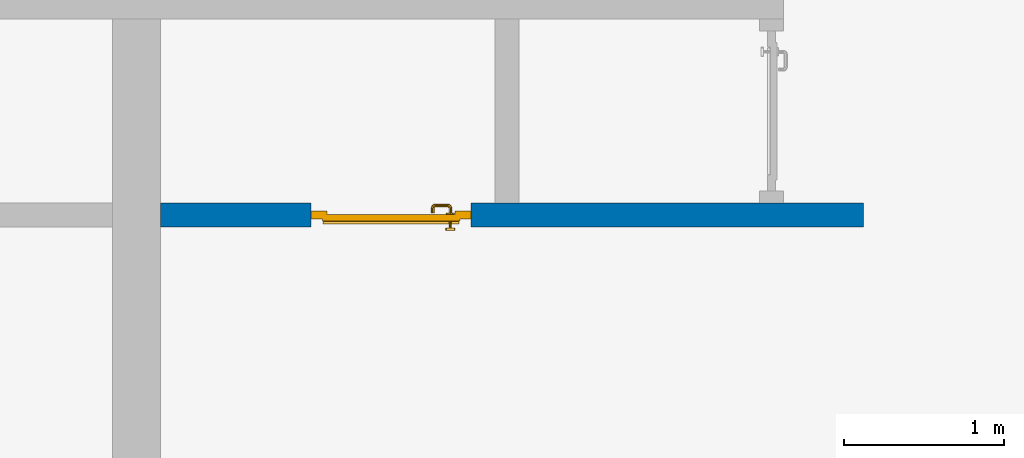
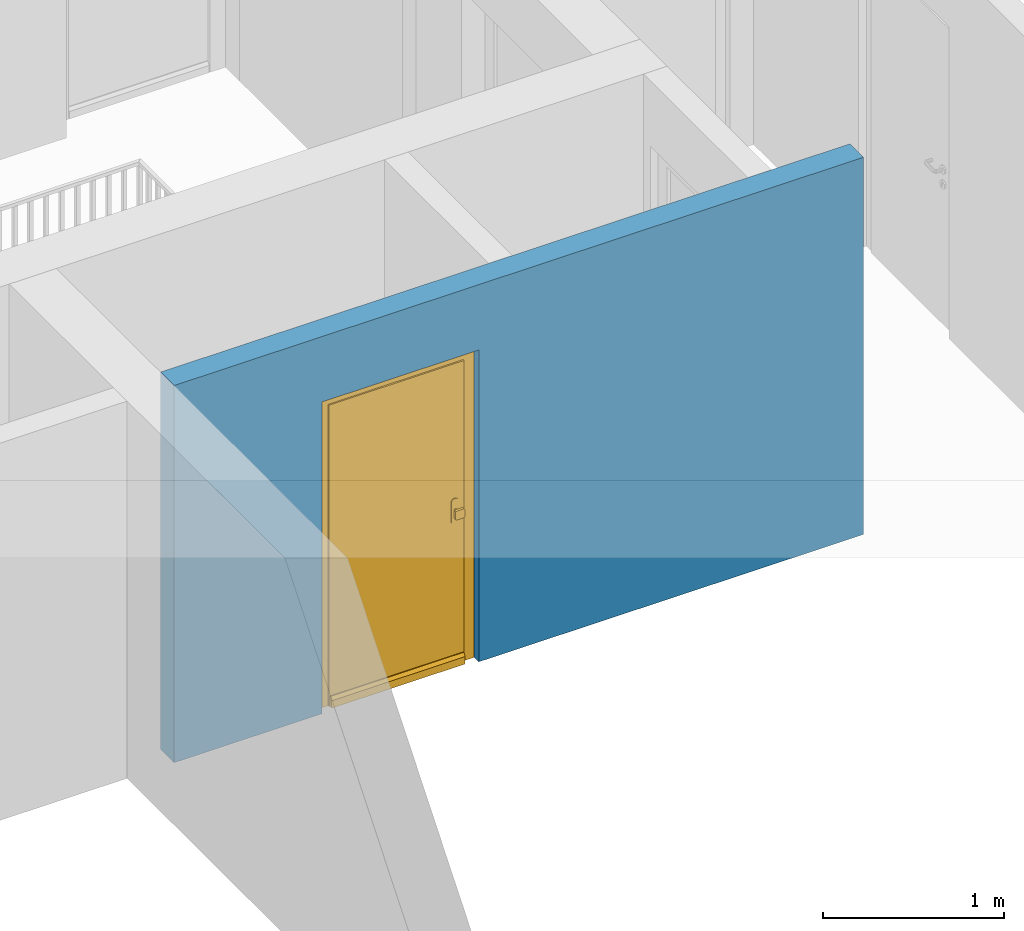
# One storey, part 3 of 54: 1 door, 1 wall, 1 opening.
"""IFC4 building model written with IfcOpenShell, lengths in metres."""

from ifc_helpers import new_model, entity, si_unit, converted_unit, derived_unit, direction, frame, origin_with_axes, place, context, subcontext, project, spatial, polygons, source, transform, mapped, material, type_object, element, fill, save


model = new_model("IFC4")

# Units and contexts
model_context = context("Model", 3, precision=1e-05, world=origin_with_axes(), true_north=direction((0.0, 1.0)))
body_context = subcontext(model_context, "Body", "Model", "MODEL_VIEW")
ifc_project = project(units=[si_unit("LENGTHUNIT", "METRE"), si_unit("AREAUNIT", "SQUARE_METRE"), si_unit("VOLUMEUNIT", "CUBIC_METRE"), converted_unit("PLANEANGLEUNIT", "DEGREE", entity("IfcPlaneAngleMeasure", 0.0174532925199), si_unit("PLANEANGLEUNIT", "RADIAN"), dimensions=[0, 0, 0, 0, 0, 0, 0]), converted_unit("TIMEUNIT", "Year", entity("IfcTimeMeasure", 31556926.0), si_unit("TIMEUNIT", "SECOND"), dimensions=[0, 0, 1, 0, 0, 0, 0]), si_unit("MASSUNIT", "GRAM", prefix="KILO"), si_unit("THERMODYNAMICTEMPERATUREUNIT", "DEGREE_CELSIUS"), si_unit("LUMINOUSINTENSITYUNIT", "LUMEN"), si_unit("ENERGYUNIT", "JOULE", prefix="MEGA"), derived_unit("THERMALCONDUCTANCEUNIT", [(si_unit("POWERUNIT", "WATT"), 1), (si_unit("LENGTHUNIT", "METRE"), -1), (si_unit("THERMODYNAMICTEMPERATUREUNIT", "KELVIN"), -1)]), derived_unit("SPECIFICHEATCAPACITYUNIT", [(si_unit("ENERGYUNIT", "JOULE"), 1), (si_unit("MASSUNIT", "GRAM", prefix="KILO"), -1), (si_unit("THERMODYNAMICTEMPERATUREUNIT", "KELVIN"), -1)]), derived_unit("MASSDENSITYUNIT", [(si_unit("MASSUNIT", "GRAM", prefix="KILO"), 1), (si_unit("VOLUMEUNIT", "CUBIC_METRE"), -1)])], contexts=[model_context])

# Site, building, storey
site_placement = place(None, origin_with_axes())
site = spatial("IfcSite", under=ifc_project, at=site_placement, CompositionType="ELEMENT")
building_placement = place(site_placement, origin_with_axes())
building = spatial("IfcBuilding", under=site, at=building_placement, CompositionType="ELEMENT")
storey_placement = place(building_placement, frame((0.0, 0.0, 9.18), z_axis=(0.0, 0.0, 1.0), x_axis=(1.0, 0.0, 0.0)))
storey = spatial("IfcBuildingStorey", under=building, at=storey_placement, Name="3. Geschoss", CompositionType="ELEMENT", Elevation=9.18)

# Wall, opening, door
ifc_material = material()
wall_type = type_object("IfcWallType", Name="150", PredefinedType="NOTDEFINED")
wall_placement = place(storey_placement, frame((-1.2021993804, -4.12881223104, 0.0), z_axis=(0.0, 0.0, 1.0), x_axis=(1.0, 0.0, 0.0)))
wall = element("IfcWall", 1, at=wall_placement, inside=storey, type_object=wall_type, material=ifc_material, Name="Wand-002", PredefinedType="NOTDEFINED", context=body_context, shape_type="Tessellation", body=[
    polygons([(1.09, 0.15, 2.1), (1.09, 0.15, 0.0), (0.15, 0.15, 0.0), (0.15, 0.15, 2.54), (4.54, 0.15, 2.54), (4.54, 0.15, 0.0), (2.09, 0.15, 0.0), (2.09, 0.15, 2.1), (1.09, 0.05, 0.0), (1.09, 0.0, 2.1), (1.09, 0.0, 0.0), (0.15, 0.0, 0.0), (0.15, 0.0, 2.54), (4.54, 0.0, 2.54), (4.54, 0.0, 0.0), (2.09, 0.05, 0.0), (2.09, 0.0, 0.0), (2.09, 0.0, 2.1)], [[[1, 2, 3, 4, 5, 6, 7, 8]], [[9, 2, 1, 10, 11]], [[2, 9, 11, 12, 3]], [[4, 3, 12, 13]], [[5, 4, 13, 14]], [[14, 15, 6, 5]], [[16, 7, 6, 15, 17]], [[8, 7, 16, 17, 18]], [[1, 8, 18, 10]], [[12, 11, 10, 18, 17, 15, 14, 13]]], closed=True),
])
opening_placement = place(wall_placement, frame((1.59, 0.0, 0.0), z_axis=(0.0, 0.0, 1.0), x_axis=(1.0, 0.0, 0.0)))
opening = element("IfcOpeningElement", 2, at=opening_placement, cuts=wall, context=body_context, identifier="Reference", shape_type="Tessellation", body=[
    polygons([(0.5, 0.05, 0.0), (0.5, 0.05, 2.1), (0.5, -0.001, 2.1), (0.5, -0.001, 0.0), (0.5, 0.151, 0.0), (0.5, 0.151, 2.1), (-0.5, 0.05, 2.1), (-0.5, -0.001, 2.1), (-0.5, 0.151, 2.1), (-0.5, -0.001, 0.0), (-0.5, 0.05, 0.0), (-0.5, 0.151, 0.0)], [[[1, 2, 3, 4]], [[2, 1, 5, 6]], [[7, 8, 3, 2, 6, 9]], [[8, 10, 4, 3]], [[1, 4, 10, 11, 12, 5]], [[6, 5, 12, 9]], [[7, 11, 10, 8]], [[11, 7, 9, 12]]], closed=True),
])
door_type = type_object("IfcDoorType", Name="Eingang 01 1-Fl 26", OperationType="SINGLE_SWING_RIGHT", PredefinedType="DOOR")
shared_shape = source(origin_with_axes(), body_context, "Body", "Tessellation", [
    polygons([(0.5, -0.05, 0.0), (0.5, -0.03, 0.0), (0.5, -0.03, 2.1), (0.5, -0.05, 2.1), (0.4, -0.05, 0.0), (0.4, -0.03, 0.0), (0.4, -0.03, 2.0), (0.1301, -0.03, 2.0), (0.0001, -0.03, 2.0), (-0.4, -0.03, 2.0), (-0.4, -0.03, 0.0), (-0.5, -0.03, 0.0), (-0.5, -0.03, 2.1), (-0.5, -0.05, 2.1), (-0.5, -0.05, 0.0), (-0.4, -0.05, 0.0), (-0.4, -0.05, 2.0), (0.0001, -0.05, 2.0), (0.1301, -0.05, 2.0), (0.4, -0.05, 2.0)], [[[1, 2, 3, 4]], [[5, 6, 2, 1]], [[2, 6, 7, 8, 9, 10, 11, 12, 13, 3]], [[4, 3, 13, 14]], [[1, 4, 14, 15, 16, 17, 18, 19, 20, 5]], [[20, 7, 6, 5]], [[19, 8, 7, 20]], [[18, 9, 8, 19]], [[17, 10, 9, 18]], [[16, 11, 10, 17]], [[15, 12, 11, 16]], [[14, 13, 12, 15]]], closed=True),
    polygons([(0.5, -0.03, 0.0), (0.5, 0.0, 0.0), (0.5, 0.0, 2.1), (0.5, -0.03, 2.1), (0.43, -0.03, 0.0), (0.43, 0.0, 0.0), (0.43, 0.0, 2.03), (0.1001, 0.0, 2.03), (0.0301, 0.0, 2.03), (-0.43, 0.0, 2.03), (-0.43, 0.0, 0.0), (-0.5, 0.0, 0.0), (-0.5, 0.0, 2.1), (-0.5, -0.03, 2.1), (-0.5, -0.03, 0.0), (-0.43, -0.03, 0.0), (-0.43, -0.03, 2.03), (0.0301, -0.03, 2.03), (0.1001, -0.03, 2.03), (0.43, -0.03, 2.03)], [[[1, 2, 3, 4]], [[5, 6, 2, 1]], [[2, 6, 7, 8, 9, 10, 11, 12, 13, 3]], [[4, 3, 13, 14]], [[1, 4, 14, 15, 16, 17, 18, 19, 20, 5]], [[20, 7, 6, 5]], [[19, 8, 7, 20]], [[18, 9, 8, 19]], [[17, 10, 9, 18]], [[16, 11, 10, 17]], [[15, 12, 11, 16]], [[14, 13, 12, 15]]], closed=True),
    polygons([(0.43, 0.01, 0.0), (-0.43, 0.01, 0.0), (-0.43, 0.01, 2.03), (0.43, 0.01, 2.03), (0.43, -0.03, 0.0), (-0.43, -0.03, 0.0), (-0.43, -0.03, 2.03), (0.43, -0.03, 2.03)], [[[1, 2, 3, 4]], [[2, 1, 5, 6]], [[3, 2, 6, 7]], [[4, 3, 7, 8]], [[1, 4, 8, 5]], [[6, 5, 8, 7]]], closed=True),
    polygons([(0.425, 0.03, 0.0), (-0.425, 0.03, 0.0), (-0.425, 0.03, 0.05), (0.425, 0.03, 0.05), (0.425, 0.01, 0.0), (-0.425, 0.01, 0.0), (-0.425, 0.01, 0.07), (-0.425, 0.015, 0.07), (0.425, 0.015, 0.07), (0.425, 0.01, 0.07)], [[[1, 2, 3, 4]], [[5, 6, 2, 1]], [[2, 6, 7, 8, 3]], [[4, 3, 8, 9]], [[1, 4, 9, 10, 5]], [[10, 7, 6, 5]], [[9, 8, 7, 10]]], closed=True),
    polygons([(-0.3835, -0.04, 1.0733826859), (-0.37, -0.04, 1.077), (-0.37, -0.0399, 1.077), (-0.3835, -0.0399, 1.0733826859), (-0.393382685902, -0.04, 1.0635), (-0.397, -0.04, 1.05), (-0.393382685902, -0.04, 1.0365), (-0.3835, -0.04, 1.0266173141), (-0.37, -0.04, 1.023), (-0.3565, -0.04, 1.0266173141), (-0.346617314098, -0.04, 1.0365), (-0.343, -0.04, 1.05), (-0.346617314098, -0.04, 1.0635), (-0.3565, -0.04, 1.0733826859), (-0.3565, -0.0399, 1.0733826859), (-0.37, -0.0301, 1.077), (-0.3835, -0.0301, 1.0733826859), (-0.393382685902, -0.0399, 1.0635), (-0.397, -0.0399, 1.05), (-0.393382685902, -0.0399, 1.0365), (-0.3835, -0.0399, 1.0266173141), (-0.37, -0.0399, 1.023), (-0.3565, -0.0399, 1.0266173141), (-0.346617314098, -0.0399, 1.0365), (-0.343, -0.0399, 1.05), (-0.346617314098, -0.0399, 1.0635), (-0.3565, -0.0301, 1.0733826859), (-0.37, -0.03, 1.077), (-0.3835, -0.03, 1.0733826859), (-0.393382685902, -0.0301, 1.0635), (-0.397, -0.0301, 1.05), (-0.393382685902, -0.0301, 1.0365), (-0.3835, -0.0301, 1.0266173141), (-0.37, -0.0301, 1.023), (-0.3565, -0.0301, 1.0266173141), (-0.346617314098, -0.0301, 1.0365), (-0.343, -0.0301, 1.05), (-0.346617314098, -0.0301, 1.0635), (-0.3565, -0.03, 1.0733826859), (-0.346617314098, -0.03, 1.0635), (-0.343, -0.03, 1.05), (-0.346617314098, -0.03, 1.0365), (-0.3565, -0.03, 1.0266173141), (-0.37, -0.03, 1.023), (-0.3835, -0.03, 1.0266173141), (-0.393382685902, -0.03, 1.0365), (-0.397, -0.03, 1.05), (-0.393382685902, -0.03, 1.0635)], [[[1, 2, 3, 4]], [[2, 1, 5, 6, 7, 8, 9, 10, 11, 12, 13, 14]], [[2, 14, 15, 3]], [[4, 3, 16, 17]], [[5, 1, 4, 18]], [[6, 5, 18, 19]], [[7, 6, 19, 20]], [[8, 7, 20, 21]], [[9, 8, 21, 22]], [[10, 9, 22, 23]], [[11, 10, 23, 24]], [[12, 11, 24, 25]], [[13, 12, 25, 26]], [[14, 13, 26, 15]], [[3, 15, 27, 16]], [[17, 16, 28, 29]], [[18, 4, 17, 30]], [[19, 18, 30, 31]], [[20, 19, 31, 32]], [[21, 20, 32, 33]], [[22, 21, 33, 34]], [[23, 22, 34, 35]], [[24, 23, 35, 36]], [[25, 24, 36, 37]], [[26, 25, 37, 38]], [[15, 26, 38, 27]], [[16, 27, 39, 28]], [[28, 39, 40, 41, 42, 43, 44, 45, 46, 47, 48, 29]], [[30, 17, 29, 48]], [[31, 30, 48, 47]], [[32, 31, 47, 46]], [[33, 32, 46, 45]], [[34, 33, 45, 44]], [[35, 34, 44, 43]], [[36, 35, 43, 42]], [[37, 36, 42, 41]], [[38, 37, 41, 40]], [[27, 38, 40, 39]]], closed=True),
    polygons([(-0.362532169224, -0.04, 0.959692280177), (-0.365, -0.04, 0.9544), (-0.365, -0.04, 0.952886751346), (-0.346703916638, -0.04, 0.96345), (-0.35655, -0.04, 0.973296083362), (-0.363279754556, -0.04, 0.961639806549), (-0.362532169224, -0.039, 0.959692280177), (-0.365, -0.039, 0.9544), (-0.365, -0.039, 0.952886751346), (-0.365, -0.039, 0.95), (-0.365, -0.039, 0.947113248654), (-0.365, -0.039, 0.941339745962), (-0.365, -0.039, 0.9375), (-0.365, -0.04, 0.9375), (-0.365, -0.04, 0.941339745962), (-0.365, -0.04, 0.947113248654), (-0.365, -0.04, 0.95), (-0.3431, -0.04, 0.95), (-0.346617314098, -0.04, 0.9635), (-0.3565, -0.04, 0.973382685902), (-0.364624817685, -0.04, 0.965143815798), (-0.37, -0.04, 0.9769), (-0.37, -0.04, 0.967425445323), (-0.364624817685, -0.039, 0.965143815798), (-0.363279754556, -0.039, 0.961639806549), (-0.35705, -0.039, 0.972430057958), (-0.347569942042, -0.039, 0.96295), (-0.3441, -0.039, 0.95), (-0.347569942042, -0.039, 0.93705), (-0.35705, -0.039, 0.927569942042), (-0.37, -0.039, 0.9241), (-0.37, -0.039, 0.9325), (-0.366464466094, -0.039, 0.933964466094), (-0.366464466094, -0.04, 0.933964466094), (-0.35655, -0.04, 0.926703916638), (-0.37, -0.04, 0.9325), (-0.37, -0.04, 0.9231), (-0.346703916638, -0.04, 0.93655), (-0.343, -0.04, 0.95), (-0.346617314098, -0.0399, 0.9635), (-0.3565, -0.0399, 0.973382685902), (-0.37, -0.04, 0.977), (-0.375375182315, -0.04, 0.965143815798), (-0.38345, -0.04, 0.973296083362), (-0.376720245444, -0.04, 0.961639806549), (-0.37, -0.039, 0.967425445323), (-0.37, -0.039, 0.9759), (-0.357, -0.039, 0.972516660498), (-0.347483339502, -0.039, 0.963), (-0.344, -0.039, 0.95), (-0.347483339502, -0.039, 0.937), (-0.357, -0.039, 0.927483339502), (-0.38295, -0.039, 0.927569942042), (-0.375, -0.039, 0.941339745962), (-0.375, -0.039, 0.9375), (-0.373535533906, -0.039, 0.933964466094), (-0.37, -0.039, 0.924), (-0.373535533906, -0.04, 0.933964466094), (-0.375, -0.04, 0.9375), (-0.375, -0.04, 0.941339745962), (-0.38345, -0.04, 0.926703916638), (-0.37, -0.04, 0.923), (-0.3565, -0.04, 0.926617314098), (-0.346617314098, -0.04, 0.9365), (-0.343, -0.0399, 0.95), (-0.346617314098, -0.0301, 0.9635), (-0.3565, -0.0301, 0.973382685902), (-0.37, -0.0399, 0.977), (-0.3835, -0.04, 0.973382685902), (-0.375375182315, -0.039, 0.965143815798), (-0.377467830776, -0.04, 0.959692280177), (-0.393296083362, -0.04, 0.96345), (-0.375, -0.04, 0.952886751346), (-0.375, -0.04, 0.9544), (-0.377467830776, -0.039, 0.959692280177), (-0.376720245444, -0.039, 0.961639806549), (-0.38295, -0.039, 0.972430057958), (-0.37, -0.039, 0.976), (-0.357, -0.0389, 0.972516660498), (-0.347483339502, -0.0389, 0.963), (-0.344, -0.0389, 0.95), (-0.347483339502, -0.0389, 0.937), (-0.357, -0.0389, 0.927483339502), (-0.392430057958, -0.039, 0.93705), (-0.375, -0.039, 0.947113248654), (-0.375, -0.039, 0.9544), (-0.375, -0.04, 0.95), (-0.375, -0.04, 0.947113248654), (-0.375, -0.039, 0.95), (-0.375, -0.039, 0.952886751346), (-0.383, -0.039, 0.927483339502), (-0.37, -0.0389, 0.924), (-0.393296083362, -0.04, 0.93655), (-0.3835, -0.04, 0.926617314098), (-0.37, -0.0399, 0.923), (-0.3565, -0.0399, 0.926617314098), (-0.346617314098, -0.0399, 0.9365), (-0.343, -0.0301, 0.95), (-0.346617314098, -0.03, 0.9635), (-0.3565, -0.03, 0.973382685902), (-0.37, -0.0301, 0.977), (-0.3835, -0.0399, 0.973382685902), (-0.393382685902, -0.04, 0.9635), (-0.3969, -0.04, 0.95), (-0.392430057958, -0.039, 0.96295), (-0.383, -0.039, 0.972516660498), (-0.37, -0.0389, 0.976), (-0.357, -0.0301, 0.972516660498), (-0.347483339502, -0.0301, 0.963), (-0.344, -0.0301, 0.95), (-0.347483339502, -0.0301, 0.937), (-0.357, -0.0301, 0.927483339502), (-0.392516660498, -0.039, 0.937), (-0.3959, -0.039, 0.95), (-0.383, -0.0389, 0.927483339502), (-0.37, -0.0301, 0.924), (-0.393382685902, -0.04, 0.9365), (-0.3835, -0.0399, 0.926617314098), (-0.37, -0.0301, 0.923), (-0.3565, -0.0301, 0.926617314098), (-0.346617314098, -0.0301, 0.9365), (-0.343, -0.03, 0.95), (-0.346703916638, -0.03, 0.96345), (-0.35655, -0.03, 0.973296083362), (-0.37, -0.03, 0.977), (-0.3835, -0.0301, 0.973382685902), (-0.393382685902, -0.0399, 0.9635), (-0.397, -0.04, 0.95), (-0.392516660498, -0.039, 0.963), (-0.383, -0.0389, 0.972516660498), (-0.37, -0.0301, 0.976), (-0.357, -0.03, 0.972516660498), (-0.347483339502, -0.03, 0.963), (-0.344, -0.03, 0.95), (-0.347483339502, -0.03, 0.937), (-0.357, -0.03, 0.927483339502), (-0.392516660498, -0.0389, 0.937), (-0.396, -0.039, 0.95), (-0.383, -0.0301, 0.927483339502), (-0.37, -0.03, 0.924), (-0.393382685902, -0.0399, 0.9365), (-0.3835, -0.0301, 0.926617314098), (-0.37, -0.03, 0.923), (-0.3565, -0.03, 0.926617314098), (-0.346617314098, -0.03, 0.9365), (-0.3431, -0.03, 0.95), (-0.347396736961, -0.03, 0.96305), (-0.35695, -0.03, 0.972603263039), (-0.37, -0.03, 0.9769), (-0.3835, -0.03, 0.973382685902), (-0.393382685902, -0.0301, 0.9635), (-0.397, -0.0399, 0.95), (-0.392516660498, -0.0389, 0.963), (-0.383, -0.0301, 0.972516660498), (-0.37, -0.03, 0.976), (-0.3439, -0.03, 0.95), (-0.347396736961, -0.03, 0.93695), (-0.35695, -0.03, 0.927396736961), (-0.392516660498, -0.0301, 0.937), (-0.396, -0.0389, 0.95), (-0.383, -0.03, 0.927483339502), (-0.37, -0.03, 0.9239), (-0.393382685902, -0.0301, 0.9365), (-0.3835, -0.03, 0.926617314098), (-0.37, -0.03, 0.9231), (-0.35655, -0.03, 0.926703916638), (-0.346703916638, -0.03, 0.93655), (-0.37, -0.03, 0.9761), (-0.38345, -0.03, 0.973296083362), (-0.393382685902, -0.03, 0.9635), (-0.397, -0.0301, 0.95), (-0.392516660498, -0.0301, 0.963), (-0.383, -0.03, 0.972516660498), (-0.392516660498, -0.03, 0.937), (-0.396, -0.0301, 0.95), (-0.38305, -0.03, 0.927396736961), (-0.393382685902, -0.03, 0.9365), (-0.38345, -0.03, 0.926703916638), (-0.38305, -0.03, 0.972603263039), (-0.393296083362, -0.03, 0.96345), (-0.397, -0.03, 0.95), (-0.392516660498, -0.03, 0.963), (-0.392603263039, -0.03, 0.93695), (-0.396, -0.03, 0.95), (-0.393296083362, -0.03, 0.93655), (-0.392603263039, -0.03, 0.96305), (-0.3969, -0.03, 0.95), (-0.3961, -0.03, 0.95)], [[[1, 2, 3, 4, 5, 6]], [[2, 1, 7, 8]], [[2, 8, 9, 10, 11, 12, 13, 14, 15, 16, 17, 3]], [[17, 18, 4, 3]], [[19, 20, 5, 4]], [[21, 6, 5, 22, 23]], [[1, 6, 21, 24, 25, 7]], [[7, 25, 26, 27, 9, 8]], [[9, 27, 28, 10]], [[10, 28, 29, 11]], [[11, 29, 30, 12]], [[31, 32, 33, 13, 12, 30]], [[14, 13, 33, 34]], [[35, 15, 14, 34, 36, 37]], [[15, 35, 38, 16]], [[16, 38, 18, 17]], [[39, 19, 4, 18]], [[40, 41, 20, 19]], [[20, 42, 22, 5]], [[43, 23, 22, 44, 45]], [[21, 23, 46, 24]], [[24, 46, 47, 26, 25]], [[27, 26, 48, 49]], [[28, 27, 49, 50]], [[29, 28, 50, 51]], [[30, 29, 51, 52]], [[53, 54, 55, 56, 32, 31]], [[34, 33, 32, 36]], [[31, 30, 52, 57]], [[37, 36, 58, 59, 60, 61]], [[62, 63, 35, 37]], [[63, 64, 38, 35]], [[64, 39, 18, 38]], [[65, 40, 19, 39]], [[66, 67, 41, 40]], [[41, 68, 42, 20]], [[42, 69, 44, 22]], [[23, 43, 70, 46]], [[71, 45, 44, 72, 73, 74]], [[43, 45, 71, 75, 76, 70]], [[70, 76, 77, 47, 46]], [[26, 47, 78, 48]], [[49, 48, 79, 80]], [[50, 49, 80, 81]], [[51, 50, 81, 82]], [[52, 51, 82, 83]], [[54, 53, 84, 85]], [[86, 74, 73, 87, 88, 60, 59, 55, 54, 85, 89, 90]], [[58, 56, 55, 59]], [[36, 32, 56, 58]], [[53, 31, 57, 91]], [[57, 52, 83, 92]], [[88, 93, 61, 60]], [[94, 62, 37, 61]], [[95, 96, 63, 62]], [[96, 97, 64, 63]], [[97, 65, 39, 64]], [[98, 66, 40, 65]], [[99, 100, 67, 66]], [[67, 101, 68, 41]], [[68, 102, 69, 42]], [[69, 103, 72, 44]], [[73, 72, 104, 87]], [[71, 74, 86, 75]], [[75, 86, 90, 105, 77, 76]], [[47, 77, 106, 78]], [[48, 78, 107, 79]], [[80, 79, 108, 109]], [[81, 80, 109, 110]], [[82, 81, 110, 111]], [[83, 82, 111, 112]], [[84, 53, 91, 113]], [[85, 84, 114, 89]], [[87, 104, 93, 88]], [[89, 114, 105, 90]], [[91, 57, 92, 115]], [[92, 83, 112, 116]], [[117, 94, 61, 93]], [[118, 95, 62, 94]], [[119, 120, 96, 95]], [[120, 121, 97, 96]], [[121, 98, 65, 97]], [[122, 99, 66, 98]], [[123, 124, 100, 99]], [[100, 125, 101, 67]], [[101, 126, 102, 68]], [[102, 127, 103, 69]], [[103, 128, 104, 72]], [[77, 105, 129, 106]], [[78, 106, 130, 107]], [[79, 107, 131, 108]], [[109, 108, 132, 133]], [[110, 109, 133, 134]], [[111, 110, 134, 135]], [[112, 111, 135, 136]], [[113, 91, 115, 137]], [[114, 84, 113, 138]], [[128, 117, 93, 104]], [[105, 114, 138, 129]], [[115, 92, 116, 139]], [[116, 112, 136, 140]], [[141, 118, 94, 117]], [[142, 119, 95, 118]], [[143, 144, 120, 119]], [[144, 145, 121, 120]], [[145, 122, 98, 121]], [[146, 123, 99, 122]], [[147, 148, 124, 123]], [[124, 149, 125, 100]], [[125, 150, 126, 101]], [[126, 151, 127, 102]], [[127, 152, 128, 103]], [[106, 129, 153, 130]], [[107, 130, 154, 131]], [[108, 131, 155, 132]], [[133, 132, 148, 147]], [[134, 133, 147, 156]], [[135, 134, 156, 157]], [[136, 135, 157, 158]], [[137, 115, 139, 159]], [[138, 113, 137, 160]], [[152, 141, 117, 128]], [[129, 138, 160, 153]], [[139, 116, 140, 161]], [[140, 136, 158, 162]], [[163, 142, 118, 141]], [[164, 143, 119, 142]], [[165, 166, 144, 143]], [[166, 167, 145, 144]], [[167, 146, 122, 145]], [[156, 147, 123, 146]], [[148, 168, 149, 124]], [[149, 169, 150, 125]], [[150, 170, 151, 126]], [[151, 171, 152, 127]], [[130, 153, 172, 154]], [[131, 154, 173, 155]], [[132, 155, 168, 148]], [[157, 156, 146, 167]], [[158, 157, 167, 166]], [[159, 139, 161, 174]], [[160, 137, 159, 175]], [[171, 163, 141, 152]], [[153, 160, 175, 172]], [[161, 140, 162, 176]], [[162, 158, 166, 165]], [[177, 164, 142, 163]], [[178, 165, 143, 164]], [[168, 179, 169, 149]], [[169, 180, 170, 150]], [[170, 181, 171, 151]], [[154, 172, 182, 173]], [[155, 173, 179, 168]], [[174, 161, 176, 183]], [[175, 159, 174, 184]], [[181, 177, 163, 171]], [[172, 175, 184, 182]], [[176, 162, 165, 178]], [[185, 178, 164, 177]], [[179, 186, 180, 169]], [[180, 187, 181, 170]], [[173, 182, 186, 179]], [[183, 176, 178, 185]], [[184, 174, 183, 188]], [[187, 185, 177, 181]], [[182, 184, 188, 186]], [[186, 188, 187, 180]], [[188, 183, 185, 187]]], closed=True),
    polygons([(-0.38, -0.04, 1.05), (-0.377071067812, -0.04, 1.04292893219), (-0.377071067812, -0.070696439392, 1.04292893219), (-0.38, -0.0709849140336, 1.05), (-0.37, -0.04, 1.04), (-0.37, -0.07, 1.04), (-0.375518993221, -0.0784992452783, 1.04292893219), (-0.378277987014, -0.0796420579258, 1.05), (-0.377071067812, -0.04, 1.05707106781), (-0.377071067812, -0.070696439392, 1.05707106781), (-0.362928932188, -0.04, 1.04292893219), (-0.362928932188, -0.069303560608, 1.04292893219), (-0.368858192988, -0.0757402514855, 1.04), (-0.370704557509, -0.0857045575088, 1.04292893219), (-0.372816199938, -0.0878161999379, 1.05), (-0.375518993221, -0.0784992452783, 1.05707106781), (-0.37, -0.04, 1.06), (-0.37, -0.07, 1.06), (-0.36, -0.04, 1.05), (-0.36, -0.0690150859664, 1.05), (-0.362197392755, -0.0729812576926, 1.04292893219), (-0.365606601718, -0.0806066017178, 1.04), (-0.363499245278, -0.0905189932208, 1.04292893219), (-0.364642057926, -0.0932779870137, 1.05), (-0.370704557509, -0.0857045575088, 1.05707106781), (-0.368858192988, -0.0757402514855, 1.06), (-0.362928932188, -0.04, 1.05707106781), (-0.362928932188, -0.069303560608, 1.05707106781), (-0.359438398962, -0.0718384450452, 1.05), (-0.360508645927, -0.0755086459268, 1.04292893219), (-0.360740251485, -0.0838581929877, 1.04), (-0.355696439392, -0.0920710678119, 1.04292893219), (-0.355984914034, -0.095, 1.05), (-0.363499245278, -0.0905189932208, 1.05707106781), (-0.365606601718, -0.0806066017178, 1.06), (-0.362197392755, -0.0729812576926, 1.05707106781), (-0.358397003498, -0.0733970034977, 1.05), (-0.357981257693, -0.0771973927545, 1.04292893219), (-0.355, -0.085, 1.04), (-0.274303560608, -0.0920710678119, 1.04292893219), (-0.274015085966, -0.095, 1.05), (-0.355696439392, -0.0920710678119, 1.05707106781), (-0.360740251485, -0.0838581929877, 1.06), (-0.360508645927, -0.0755086459268, 1.05707106781), (-0.356838445045, -0.0744383989617, 1.05), (-0.354303560608, -0.0779289321881, 1.04292893219), (-0.275, -0.085, 1.04), (-0.266500754722, -0.0905189932208, 1.04292893219), (-0.265357942074, -0.0932779870137, 1.05), (-0.274303560608, -0.0920710678119, 1.05707106781), (-0.355, -0.085, 1.06), (-0.357981257693, -0.0771973927545, 1.05707106781), (-0.354015085966, -0.075, 1.05), (-0.275696439392, -0.0779289321881, 1.04292893219), (-0.269259748515, -0.0838581929877, 1.04), (-0.259295442491, -0.0857045575088, 1.04292893219), (-0.257183800062, -0.0878161999379, 1.05), (-0.266500754722, -0.0905189932208, 1.05707106781), (-0.275, -0.085, 1.06), (-0.354303560608, -0.0779289321881, 1.05707106781), (-0.275984914034, -0.075, 1.05), (-0.272018742307, -0.0771973927545, 1.04292893219), (-0.264393398282, -0.0806066017178, 1.04), (-0.254481006779, -0.0784992452783, 1.04292893219), (-0.251722012986, -0.0796420579258, 1.05), (-0.259295442491, -0.0857045575088, 1.05707106781), (-0.269259748515, -0.0838581929877, 1.06), (-0.275696439392, -0.0779289321881, 1.05707106781), (-0.273161554955, -0.0744383989617, 1.05), (-0.269491354073, -0.0755086459268, 1.04292893219), (-0.261141807012, -0.0757402514855, 1.04), (-0.252928932188, -0.070696439392, 1.04292893219), (-0.25, -0.0709849140336, 1.05), (-0.254481006779, -0.0784992452783, 1.05707106781), (-0.264393398282, -0.0806066017178, 1.06), (-0.272018742307, -0.0771973927545, 1.05707106781), (-0.271602996502, -0.0733970034977, 1.05), (-0.267802607245, -0.0729812576926, 1.04292893219), (-0.26, -0.07, 1.04), (-0.252928932188, -0.04, 1.04292893219), (-0.25, -0.04, 1.05), (-0.252928932188, -0.070696439392, 1.05707106781), (-0.261141807012, -0.0757402514855, 1.06), (-0.269491354073, -0.0755086459268, 1.05707106781), (-0.270561601038, -0.0718384450452, 1.05), (-0.267071067812, -0.069303560608, 1.04292893219), (-0.26, -0.04, 1.04), (-0.267071067812, -0.04, 1.04292893219), (-0.27, -0.04, 1.05), (-0.267071067812, -0.04, 1.05707106781), (-0.26, -0.04, 1.06), (-0.252928932188, -0.04, 1.05707106781), (-0.26, -0.07, 1.06), (-0.267802607245, -0.0729812576926, 1.05707106781), (-0.27, -0.0690150859664, 1.05), (-0.267071067812, -0.069303560608, 1.05707106781)], [[[1, 2, 3, 4]], [[2, 5, 6, 3]], [[4, 3, 7, 8]], [[9, 1, 4, 10]], [[5, 11, 12, 6]], [[3, 6, 13, 7]], [[8, 7, 14, 15]], [[10, 4, 8, 16]], [[17, 9, 10, 18]], [[11, 19, 20, 12]], [[6, 12, 21, 13]], [[7, 13, 22, 14]], [[15, 14, 23, 24]], [[16, 8, 15, 25]], [[18, 10, 16, 26]], [[27, 17, 18, 28]], [[19, 27, 28, 20]], [[12, 20, 29, 21]], [[13, 21, 30, 22]], [[14, 22, 31, 23]], [[24, 23, 32, 33]], [[25, 15, 24, 34]], [[26, 16, 25, 35]], [[28, 18, 26, 36]], [[20, 28, 36, 29]], [[21, 29, 37, 30]], [[22, 30, 38, 31]], [[23, 31, 39, 32]], [[33, 32, 40, 41]], [[34, 24, 33, 42]], [[35, 25, 34, 43]], [[36, 26, 35, 44]], [[29, 36, 44, 37]], [[30, 37, 45, 38]], [[31, 38, 46, 39]], [[32, 39, 47, 40]], [[41, 40, 48, 49]], [[42, 33, 41, 50]], [[43, 34, 42, 51]], [[44, 35, 43, 52]], [[37, 44, 52, 45]], [[38, 45, 53, 46]], [[39, 46, 54, 47]], [[40, 47, 55, 48]], [[49, 48, 56, 57]], [[50, 41, 49, 58]], [[51, 42, 50, 59]], [[52, 43, 51, 60]], [[45, 52, 60, 53]], [[46, 53, 61, 54]], [[47, 54, 62, 55]], [[48, 55, 63, 56]], [[57, 56, 64, 65]], [[58, 49, 57, 66]], [[59, 50, 58, 67]], [[60, 51, 59, 68]], [[53, 60, 68, 61]], [[54, 61, 69, 62]], [[55, 62, 70, 63]], [[56, 63, 71, 64]], [[65, 64, 72, 73]], [[66, 57, 65, 74]], [[67, 58, 66, 75]], [[68, 59, 67, 76]], [[61, 68, 76, 69]], [[62, 69, 77, 70]], [[63, 70, 78, 71]], [[64, 71, 79, 72]], [[73, 72, 80, 81]], [[74, 65, 73, 82]], [[75, 66, 74, 83]], [[76, 67, 75, 84]], [[69, 76, 84, 77]], [[70, 77, 85, 78]], [[71, 78, 86, 79]], [[72, 79, 87, 80]], [[81, 80, 87, 88, 89, 90, 91, 92]], [[82, 73, 81, 92]], [[83, 74, 82, 93]], [[84, 75, 83, 94]], [[77, 84, 94, 85]], [[78, 85, 95, 86]], [[79, 86, 88, 87]], [[86, 95, 89, 88]], [[95, 96, 90, 89]], [[96, 93, 91, 90]], [[93, 82, 92, 91]], [[94, 83, 93, 96]], [[85, 94, 96, 95]]], closed=False),
    polygons([(-0.364696699141, 0.015, 1.04469669914), (-0.3625, 0.015, 1.05), (-0.364696699141, 0.015, 1.05530330086), (-0.37, 0.015, 1.0575), (-0.375303300859, 0.015, 1.05530330086), (-0.3775, 0.015, 1.05), (-0.375303300859, 0.015, 1.04469669914), (-0.37, 0.015, 1.0425), (-0.364696699141, 0.055, 1.04469669914), (-0.3625, 0.055, 1.05), (-0.364696699141, 0.055, 1.05530330086), (-0.37, 0.055, 1.0575), (-0.375303300859, 0.055, 1.05530330086), (-0.3775, 0.055, 1.05), (-0.375303300859, 0.055, 1.04469669914), (-0.37, 0.055, 1.0425)], [[[1, 2, 3, 4, 5, 6, 7, 8]], [[1, 9, 10, 2]], [[2, 10, 11, 3]], [[3, 11, 12, 4]], [[4, 12, 13, 5]], [[5, 13, 14, 6]], [[6, 14, 15, 7]], [[7, 15, 16, 8]], [[8, 16, 9, 1]], [[9, 16, 15, 14, 13, 12, 11, 10]]], closed=True),
    polygons([(-0.395, 0.01, 0.975), (-0.395, 0.015, 0.975), (-0.393096988313, 0.015, 0.965432914191), (-0.393096988313, 0.01, 0.965432914191), (-0.395, 0.01, 1.1), (-0.395, 0.015, 1.1), (-0.393096988313, 0.015, 1.10956708581), (-0.38767766953, 0.015, 1.11767766953), (-0.379567085809, 0.015, 1.12309698831), (-0.37, 0.015, 1.125), (-0.360432914191, 0.015, 1.12309698831), (-0.35232233047, 0.015, 1.11767766953), (-0.346903011687, 0.015, 1.10956708581), (-0.345, 0.015, 1.1), (-0.345, 0.015, 0.975), (-0.346903011687, 0.015, 0.965432914191), (-0.35232233047, 0.015, 0.95732233047), (-0.360432914191, 0.015, 0.951903011687), (-0.37, 0.015, 0.95), (-0.379567085809, 0.015, 0.951903011687), (-0.38767766953, 0.015, 0.95732233047), (-0.38767766953, 0.01, 0.95732233047), (-0.379567085809, 0.01, 0.951903011687), (-0.37, 0.01, 0.95), (-0.360432914191, 0.01, 0.951903011687), (-0.35232233047, 0.01, 0.95732233047), (-0.346903011687, 0.01, 0.965432914191), (-0.345, 0.01, 0.975), (-0.345, 0.01, 1.1), (-0.346903011687, 0.01, 1.10956708581), (-0.35232233047, 0.01, 1.11767766953), (-0.360432914191, 0.01, 1.12309698831), (-0.37, 0.01, 1.125), (-0.379567085809, 0.01, 1.12309698831), (-0.38767766953, 0.01, 1.11767766953), (-0.393096988313, 0.01, 1.10956708581)], [[[1, 2, 3, 4]], [[5, 6, 2, 1]], [[2, 6, 7, 8, 9, 10, 11, 12, 13, 14, 15, 16, 17, 18, 19, 20, 21, 3]], [[4, 3, 21, 22]], [[1, 4, 22, 23, 24, 25, 26, 27, 28, 29, 30, 31, 32, 33, 34, 35, 36, 5]], [[36, 7, 6, 5]], [[35, 8, 7, 36]], [[34, 9, 8, 35]], [[33, 10, 9, 34]], [[32, 11, 10, 33]], [[31, 12, 11, 32]], [[30, 13, 12, 31]], [[29, 14, 13, 30]], [[28, 15, 14, 29]], [[27, 16, 15, 28]], [[26, 17, 16, 27]], [[25, 18, 17, 26]], [[24, 19, 18, 25]], [[23, 20, 19, 24]], [[22, 21, 20, 23]]], closed=True),
    polygons([(-0.39, 0.055, 1.08), (-0.39, 0.07, 1.08), (-0.395, 0.07, 1.07866025404), (-0.395, 0.055, 1.07866025404), (-0.35, 0.055, 1.08), (-0.35, 0.07, 1.08), (-0.345, 0.07, 1.07866025404), (-0.341339745962, 0.07, 1.075), (-0.34, 0.07, 1.07), (-0.34, 0.07, 1.03), (-0.341339745962, 0.07, 1.025), (-0.345, 0.07, 1.02133974596), (-0.35, 0.07, 1.02), (-0.39, 0.07, 1.02), (-0.395, 0.07, 1.02133974596), (-0.398660254038, 0.07, 1.025), (-0.4, 0.07, 1.03), (-0.4, 0.07, 1.07), (-0.398660254038, 0.07, 1.075), (-0.398660254038, 0.055, 1.075), (-0.4, 0.055, 1.07), (-0.4, 0.055, 1.03), (-0.398660254038, 0.055, 1.025), (-0.395, 0.055, 1.02133974596), (-0.39, 0.055, 1.02), (-0.35, 0.055, 1.02), (-0.345, 0.055, 1.02133974596), (-0.341339745962, 0.055, 1.025), (-0.34, 0.055, 1.03), (-0.34, 0.055, 1.07), (-0.341339745962, 0.055, 1.075), (-0.345, 0.055, 1.07866025404)], [[[1, 2, 3, 4]], [[5, 6, 2, 1]], [[2, 6, 7, 8, 9, 10, 11, 12, 13, 14, 15, 16, 17, 18, 19, 3]], [[4, 3, 19, 20]], [[1, 4, 20, 21, 22, 23, 24, 25, 26, 27, 28, 29, 30, 31, 32, 5]], [[32, 7, 6, 5]], [[31, 8, 7, 32]], [[30, 9, 8, 31]], [[29, 10, 9, 30]], [[28, 11, 10, 29]], [[27, 12, 11, 28]], [[26, 13, 12, 27]], [[25, 14, 13, 26]], [[24, 15, 14, 25]], [[23, 16, 15, 24]], [[22, 17, 16, 23]], [[21, 18, 17, 22]], [[20, 19, 18, 21]]], closed=True),
])
door_placement = place(opening_placement, frame((0.4, 0.0, 0.0), z_axis=(0.0, 0.0, 1.0), x_axis=(-1.0, 0.0, 0.0)))
door = element("IfcDoor", 3, at=door_placement, inside=storey, type_object=door_type, OverallHeight=2.1, OverallWidth=1.0, PredefinedType="DOOR", context=body_context, shape_type="MappedRepresentation", body=[
    mapped(shared_shape, transform((0.4, -0.05, 0.0))),
])
fill(opening, door)

save(model, "model.ifc")
